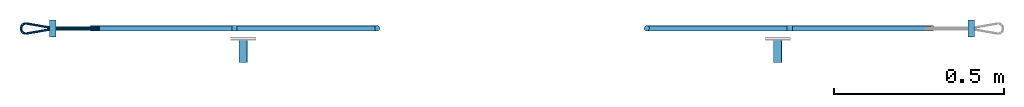
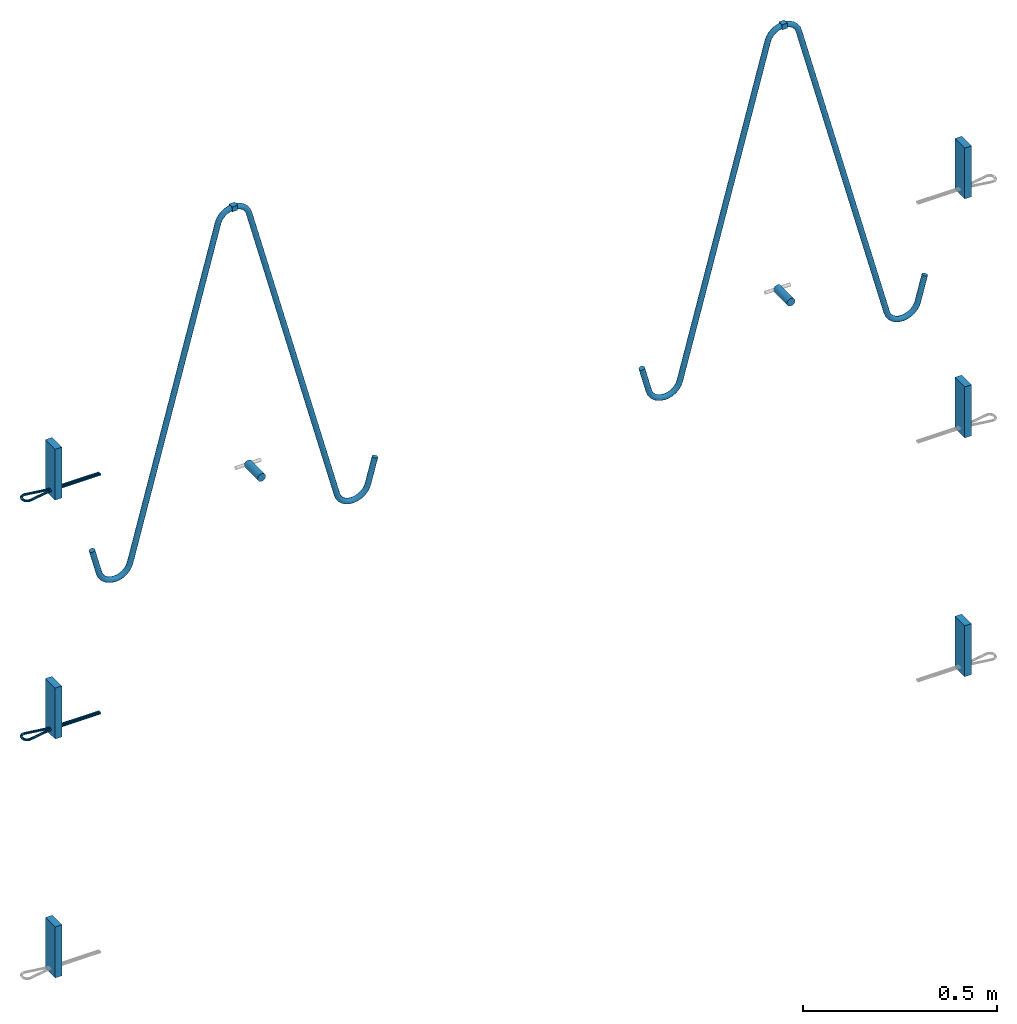
# One storey, part 1 of 2: 6 plates, 4 beams, 4 reinforcing bars, 10 elements without a shape of their own.
"""IFC2X3 building model written with IfcOpenShell, lengths in millimetres."""

from ifc_helpers import new_model, entity, si_unit, frame, frame_2d, origin_with_axes, place, context, subcontext, project, spatial, polyline, rectangle, circle, outline, extrude, source, transform, mapped, material, type_object, element, aggregate, save


model = new_model("IFC2X3")

# Units and contexts
model_context = context("Model", 3, precision=1e-05, world=origin_with_axes())
body_context = subcontext(model_context, "Body", "Model", "MODEL_VIEW")
ifc_project = project(units=[si_unit("LENGTHUNIT", "METRE", prefix="MILLI"), si_unit("AREAUNIT", "SQUARE_METRE"), si_unit("VOLUMEUNIT", "CUBIC_METRE"), si_unit("MASSUNIT", "GRAM", prefix="KILO"), si_unit("TIMEUNIT", "SECOND"), si_unit("PLANEANGLEUNIT", "RADIAN"), si_unit("SOLIDANGLEUNIT", "STERADIAN"), si_unit("THERMODYNAMICTEMPERATUREUNIT", "DEGREE_CELSIUS"), si_unit("LUMINOUSINTENSITYUNIT", "LUMEN")], contexts=[model_context])

# Site, building, storey
site_placement = place(None, origin_with_axes())
site = spatial("IfcSite", under=ifc_project, at=site_placement, CompositionType="ELEMENT")
building_placement = place(site_placement, origin_with_axes())
building = spatial("IfcBuilding", under=site, at=building_placement, Name="Undefined", CompositionType="ELEMENT")
storey_placement = place(building_placement, origin_with_axes())
storey = spatial("IfcBuildingStorey", under=building, at=storey_placement, Name="Undefined", CompositionType="ELEMENT", Elevation=0.0)

# Assembly, beam
assembly_1_placement = place(storey_placement, origin_with_axes())
assembly_1 = element("IfcElementAssembly", 1, at=assembly_1_placement, inside=storey, Name="Steel Assembly", AssemblyPlace="NOTDEFINED", PredefinedType="RIGID_FRAME")
ifc_material_1 = material(Name="STEEL/S235JR")
beam_type_1 = type_object("IfcBeamType", Name="16X16", PredefinedType="NOTDEFINED")
beam_1_placement = place(assembly_1_placement, frame((38185.0997792359, 100.538788960472, 2796.99979437718), z_axis=(0.0, 0.0, 1.0), x_axis=(-0.999999999974582, 7.12999999981878e-06, -1.1000000085717e-08)))
beam_1 = element("IfcBeam", 2, at=beam_1_placement, type_object=beam_type_1, material=ifc_material_1, Name="SA_16", ObjectType="16X16", context=body_context, shape_type="SweptSolid", body=[
    extrude(rectangle(XDim=16.0, YDim=16.0, at=frame_2d((-2.95871700473072e-08, -3.27418092638254e-10), x_axis=(1.0, 0.0))), frame((15.9999999997114, 6.69320834167074e-22, -4.54747350886464e-13), z_axis=(-1.0, 1.47560875081975e-12, 2.33086648627995e-12), x_axis=(-1.47560875081972e-12, -1.0, 1.02406159234497e-14)), (0.0, 0.0, 1.0), 16.0),
])

assembly_2_placement = place(storey_placement, origin_with_axes())
assembly_2 = element("IfcElementAssembly", 3, at=assembly_2_placement, inside=storey, Name="Steel Assembly", AssemblyPlace="NOTDEFINED", PredefinedType="RIGID_FRAME")
beam_2_placement = place(assembly_2_placement, frame((36536.3494963368, 100.550900671999, 2796.99977627339), z_axis=(0.0, 0.0, 1.0), x_axis=(0.999999999973077, -7.33799999980014e-06, 1.10000000860345e-08)))
beam_2 = element("IfcBeam", 4, at=beam_2_placement, type_object=beam_type_1, material=ifc_material_1, Name="SA_16", ObjectType="16X16", context=body_context, shape_type="SweptSolid", body=[
    extrude(rectangle(XDim=16.0, YDim=16.0, at=frame_2d((-2.95871700473072e-08, -3.27418092638254e-10), x_axis=(1.0, 0.0))), frame((15.9999999997114, 6.69320834167074e-22, -4.54747350886464e-13), z_axis=(-1.0, 1.47560875081975e-12, 2.33086648627995e-12), x_axis=(-1.47560875081972e-12, -1.0, 1.02406159234497e-14)), (0.0, 0.0, 1.0), 16.0),
])

assembly_3_placement = place(storey_placement, origin_with_axes())
assembly_3 = element("IfcElementAssembly", 5, at=assembly_3_placement, inside=storey, Name="Steel Assembly", AssemblyPlace="NOTDEFINED", PredefinedType="RIGID_FRAME")
beam_type_2 = type_object("IfcBeamType", Name="D24", PredefinedType="NOTDEFINED")
beam_3_placement = place(assembly_3_placement, frame((38142.136472481, -0.0238731479991401, 1999.99979398687), z_axis=(0.0, 0.0, 1.0), x_axis=(7.33799999579833e-06, 0.999999999973077, 0.0)))
beam_3 = element("IfcBeam", 6, at=beam_3_placement, type_object=beam_type_2, material=ifc_material_1, ObjectType="D24", context=body_context, shape_type="SweptSolid", body=[
    extrude(circle(Radius=12.0, at=frame_2d((-2.95871700473072e-08, -3.27418092638254e-10), x_axis=(1.0, 0.0))), frame((69.9999999988867, 0.0, -2.27373675443232e-13), z_axis=(-1.0, 1.47560875081975e-12, 2.33086648627995e-12), x_axis=(-1.47560875081972e-12, -1.0, 1.02406159234497e-14)), (0.0, 0.0, 1.0), 70.0),
])
aggregate(assembly_3, [beam_3])

assembly_4_placement = place(storey_placement, origin_with_axes())
assembly_4 = element("IfcElementAssembly", 7, at=assembly_4_placement, inside=storey, Name="Steel Assembly", AssemblyPlace="NOTDEFINED", PredefinedType="RIGID_FRAME")
beam_4_placement = place(assembly_4_placement, frame((36569.99647256, -0.00839933236845525, 1999.99977669372), z_axis=(0.0, 0.0, 1.0), x_axis=(7.33799999579833e-06, 0.999999999973077, 0.0)))
beam_4 = element("IfcBeam", 8, at=beam_4_placement, type_object=beam_type_2, material=ifc_material_1, ObjectType="D24", context=body_context, shape_type="SweptSolid", body=[
    extrude(circle(Radius=12.0, at=frame_2d((-2.95871700473072e-08, -3.27418092638254e-10), x_axis=(1.0, 0.0))), frame((69.9999999988867, 0.0, -2.27373675443232e-13), z_axis=(-1.0, 1.47560875081975e-12, 2.33086648627995e-12), x_axis=(-1.47560875081972e-12, -1.0, 1.02406159234497e-14)), (0.0, 0.0, 1.0), 70.0),
])
aggregate(assembly_4, [beam_4])

# Assembly, plate
assembly_5_placement = place(storey_placement, origin_with_axes())
assembly_5 = element("IfcElementAssembly", 9, at=assembly_5_placement, inside=storey, Name="Steel Assembly", AssemblyPlace="NOTDEFINED", PredefinedType="RIGID_FRAME")
ifc_material_2 = material(Name="STEEL/Steel_Undefined")
plate_type = type_object("IfcPlateType", Name="PL160X20", PredefinedType="NOTDEFINED")
plate_1_placement = place(assembly_5_placement, frame((38721.2513597076, 124.979744641962, 2162.49980033677), z_axis=(1.10000000856349e-08, -7.84300007522065e-14, -1.0), x_axis=(-7.13000001269421e-06, -0.999999999974582, 0.0)))
plate_1 = element("IfcPlate", 10, at=plate_1_placement, type_object=plate_type, material=ifc_material_2, Name="PVL80", ObjectType="PL160X20", context=body_context, shape_type="SweptSolid", body=[
    extrude(outline(polyline([(-2.95871700473072e-08, -3.27418092638254e-10), (49.9999999704114, -1.38243194669485e-10), (49.9999999704492, 20.000000000291), (-2.96426065915512e-08, 20.0000000001019), (-2.95871700473072e-08, -3.27418092638254e-10)])), frame((-1.0097419586829e-27, -7.27595761418343e-12, -80.0), z_axis=(0.0, 0.0, 1.0), x_axis=(1.0, 0.0, 0.0)), (0.0, 0.0, 1.0), 160.0),
])
aggregate(assembly_5, [plate_1])

assembly_6_placement = place(storey_placement, origin_with_axes())
assembly_6 = element("IfcElementAssembly", 11, at=assembly_6_placement, inside=storey, Name="Steel Assembly", AssemblyPlace="NOTDEFINED", PredefinedType="RIGID_FRAME")
plate_2_placement = place(assembly_6_placement, frame((38721.2513679684, 124.979744980204, 1412.49980033928), z_axis=(1.10000000856349e-08, -7.84300007522065e-14, -1.0), x_axis=(-7.13000001269421e-06, -0.999999999974582, 0.0)))
plate_2 = element("IfcPlate", 12, at=plate_2_placement, type_object=plate_type, material=ifc_material_2, Name="PVL80", ObjectType="PL160X20", context=body_context, shape_type="SweptSolid", body=[
    extrude(outline(polyline([(-2.95871700473072e-08, -3.27418092638254e-10), (49.9999999704114, -1.38243194669485e-10), (49.9999999704492, 20.000000000291), (-2.96426065915512e-08, 20.0000000001019), (-2.95871700473072e-08, -3.27418092638254e-10)])), frame((-1.0097419586829e-27, -7.27595761418343e-12, -80.0), z_axis=(0.0, 0.0, 1.0), x_axis=(1.0, 0.0, 0.0)), (0.0, 0.0, 1.0), 160.0),
])
aggregate(assembly_6, [plate_2])

assembly_7_placement = place(storey_placement, origin_with_axes())
assembly_7 = element("IfcElementAssembly", 13, at=assembly_7_placement, inside=storey, Name="Steel Assembly", AssemblyPlace="NOTDEFINED", PredefinedType="RIGID_FRAME")
plate_3_placement = place(assembly_7_placement, frame((38721.2513762134, 124.979745351619, 662.499800336753), z_axis=(1.10000000856349e-08, -7.84300007522065e-14, -1.0), x_axis=(-7.13000001269421e-06, -0.999999999974582, 0.0)))
plate_3 = element("IfcPlate", 14, at=plate_3_placement, type_object=plate_type, material=ifc_material_2, Name="PVL80", ObjectType="PL160X20", context=body_context, shape_type="SweptSolid", body=[
    extrude(outline(polyline([(-2.95871700473072e-08, -3.27418092638254e-10), (49.9999999704114, -1.38243194669485e-10), (49.9999999704492, 20.000000000291), (-2.96426065915512e-08, 20.0000000001019), (-2.95871700473072e-08, -3.27418092638254e-10)])), frame((-1.0097419586829e-27, -7.27595761418343e-12, -80.0), z_axis=(0.0, 0.0, 1.0), x_axis=(1.0, 0.0, 0.0)), (0.0, 0.0, 1.0), 160.0),
])
aggregate(assembly_7, [plate_3])

assembly_8_placement = place(storey_placement, origin_with_axes())
assembly_8 = element("IfcElementAssembly", 15, at=assembly_8_placement, inside=storey, Name="Steel Assembly", AssemblyPlace="NOTDEFINED", PredefinedType="RIGID_FRAME")
plate_4_placement = place(assembly_8_placement, frame((36000.0005263411, 74.9997413660697, 2162.49977037731), z_axis=(1.10000000856349e-08, -7.84300007522065e-14, -1.0), x_axis=(7.33799999579833e-06, 0.999999999973077, 0.0)))
plate_4 = element("IfcPlate", 16, at=plate_4_placement, type_object=plate_type, material=ifc_material_2, Name="PVL80", ObjectType="PL160X20", context=body_context, shape_type="SweptSolid", body=[
    extrude(outline(polyline([(-2.95871700473072e-08, -3.27418092638254e-10), (49.9999999704114, -1.38243194669485e-10), (49.9999999704492, 20.000000000291), (-2.96426065915512e-08, 20.0000000001019), (-2.95871700473072e-08, -3.27418092638254e-10)])), frame((-1.0097419586829e-27, -7.27595761418343e-12, -80.0), z_axis=(0.0, 0.0, 1.0), x_axis=(1.0, 0.0, 0.0)), (0.0, 0.0, 1.0), 160.0),
])

assembly_9_placement = place(storey_placement, origin_with_axes())
assembly_9 = element("IfcElementAssembly", 17, at=assembly_9_placement, inside=storey, Name="Steel Assembly", AssemblyPlace="NOTDEFINED", PredefinedType="RIGID_FRAME")
plate_5_placement = place(assembly_9_placement, frame((36000.0005345941, 74.9997417209221, 1412.49977037732), z_axis=(1.10000000856349e-08, -7.84300007522065e-14, -1.0), x_axis=(7.33799999579833e-06, 0.999999999973077, 0.0)))
plate_5 = element("IfcPlate", 18, at=plate_5_placement, type_object=plate_type, material=ifc_material_2, Name="PVL80", ObjectType="PL160X20", context=body_context, shape_type="SweptSolid", body=[
    extrude(outline(polyline([(-2.95871700473072e-08, -3.27418092638254e-10), (49.9999999704114, -1.38243194669485e-10), (49.9999999704492, 20.000000000291), (-2.96426065915512e-08, 20.0000000001019), (-2.95871700473072e-08, -3.27418092638254e-10)])), frame((-1.0097419586829e-27, -7.27595761418343e-12, -80.0), z_axis=(0.0, 0.0, 1.0), x_axis=(1.0, 0.0, 0.0)), (0.0, 0.0, 1.0), 160.0),
])

assembly_10_placement = place(storey_placement, origin_with_axes())
assembly_10 = element("IfcElementAssembly", 19, at=assembly_10_placement, inside=storey, Name="Steel Assembly", AssemblyPlace="NOTDEFINED", PredefinedType="RIGID_FRAME")
plate_6_placement = place(assembly_10_placement, frame((36000.000542847, 74.9997420757317, 662.499770377318), z_axis=(1.10000000856349e-08, -7.84300007522065e-14, -1.0), x_axis=(7.33799999579833e-06, 0.999999999973077, 0.0)))
plate_6 = element("IfcPlate", 20, at=plate_6_placement, type_object=plate_type, material=ifc_material_2, Name="PVL80", ObjectType="PL160X20", context=body_context, shape_type="SweptSolid", body=[
    extrude(outline(polyline([(-2.95871700473072e-08, -3.27418092638254e-10), (49.9999999704114, -1.38243194669485e-10), (49.9999999704492, 20.000000000291), (-2.96426065915512e-08, 20.0000000001019), (-2.95871700473072e-08, -3.27418092638254e-10)])), frame((-1.0097419586829e-27, -7.27595761418343e-12, -80.0), z_axis=(0.0, 0.0, 1.0), x_axis=(1.0, 0.0, 0.0)), (0.0, 0.0, 1.0), 160.0),
])
aggregate(assembly_10, [plate_6])

# Reinforcing bar
ifc_material_3 = material(Name="Undefined")
ifc_direction_1 = entity("IfcDirection", [-1.0, 1.47560875081975e-12, 2.33086648627995e-12])
ifc_direction_2 = entity("IfcDirection", [-1.47560875081972e-12, -1.0, 1.02406159234497e-14])
ifc_direction_3 = entity("IfcDirection", [0.0, 0.0, 1.0])
ifc_direction_4 = entity("IfcDirection", [0.0, 1.0, 0.0])
shared_shape_1 = source(origin_with_axes(), body_context, "Body", "AdvancedSweptSolid", [
    entity("IfcSweptDiskSolid", entity("IfcCompositeCurve", [entity("IfcCompositeCurveSegment", "CONTINUOUS", True, entity("IfcTrimmedCurve", entity("IfcLine", entity("IfcCartesianPoint", [0.0, 0.0, 0.0]), entity("IfcVector", ifc_direction_1, 1.0)), [entity("IfcParameterValue", 0.0)], [entity("IfcParameterValue", 145.829645725194)], True, "PARAMETER")), entity("IfcCompositeCurveSegment", "CONTINUOUS", True, entity("IfcTrimmedCurve", entity("IfcCircle", entity("IfcAxis2Placement3D", entity("IfcCartesianPoint", [-145.829645727792, 2.15049253049908e-10, -13.4999999996601]), ifc_direction_2, ifc_direction_3), 13.5), [entity("IfcParameterValue", 0.0)], [entity("IfcParameterValue", 0.172953396989496)], True, "PARAMETER")), entity("IfcCompositeCurveSegment", "CONTINUOUS", True, entity("IfcTrimmedCurve", entity("IfcLine", entity("IfcCartesianPoint", [-148.152893533644, 2.18613643604162e-10, -0.201409110674614]), entity("IfcVector", entity("IfcDirection", [-0.985080806591517, 1.45183152599139e-12, -0.172092430063053]), 1.0)), [entity("IfcParameterValue", 0.0)], [entity("IfcParameterValue", 67.0237996921062)], True, "PARAMETER")), entity("IfcCompositeCurveSegment", "CONTINUOUS", True, entity("IfcTrimmedCurve", entity("IfcCircle", entity("IfcAxis2Placement3D", entity("IfcCartesianPoint", [-216.500000002484, 3.19344957439298e-10, 1.56289321698179]), ifc_direction_4, entity("IfcDirection", [0.172092430063053, -2.53633218389051e-13, -0.985080806591517])), 13.5), [entity("IfcParameterValue", 0.0)], [entity("IfcParameterValue", 1.74374972377907)], True, "PARAMETER")), entity("IfcCompositeCurveSegment", "CONTINUOUS", True, entity("IfcTrimmedCurve", entity("IfcLine", entity("IfcCartesianPoint", [-230.000000002484, 3.39241523761302e-10, 1.56289321697337]), entity("IfcVector", ifc_direction_3, 1.0)), [entity("IfcParameterValue", 0.0)], [entity("IfcParameterValue", 2.87421356693589)], True, "PARAMETER")), entity("IfcCompositeCurveSegment", "CONTINUOUS", True, entity("IfcTrimmedCurve", entity("IfcCircle", entity("IfcAxis2Placement3D", entity("IfcCartesianPoint", [-216.500000002486, 3.19344957439299e-10, 4.43710678401381]), ifc_direction_4, ifc_direction_1), 13.5), [entity("IfcParameterValue", 0.0)], [entity("IfcParameterValue", 1.74374972378939)], True, "PARAMETER")), entity("IfcCompositeCurveSegment", "CONTINUOUS", True, entity("IfcTrimmedCurve", entity("IfcLine", entity("IfcCartesianPoint", [-214.176752196575, 3.15920908990935e-10, 17.7356976729889]), entity("IfcVector", entity("IfcDirection", [0.985080806590746, -1.45183152598987e-12, -0.172092430067466]), 1.0)), [entity("IfcParameterValue", 0.0)], [entity("IfcParameterValue", 67.0237996920936)], True, "PARAMETER")), entity("IfcCompositeCurveSegment", "CONTINUOUS", True, entity("IfcTrimmedCurve", entity("IfcCircle", entity("IfcAxis2Placement3D", entity("IfcCartesianPoint", [-145.829645727731, 2.15049253049787e-10, 19.5000000003398]), ifc_direction_2, entity("IfcDirection", [-0.172092430067466, 2.64028929953437e-13, -0.985080806590746])), 13.5), [entity("IfcParameterValue", 0.0)], [entity("IfcParameterValue", 0.172953396989178)], True, "PARAMETER")), entity("IfcCompositeCurveSegment", "DISCONTINUOUS", True, entity("IfcTrimmedCurve", entity("IfcLine", entity("IfcCartesianPoint", [-145.829645727762, 2.1518750136483e-10, 6.00000000033984]), entity("IfcVector", entity("IfcDirection", [1.0, 0.0, 0.0]), 1.0)), [entity("IfcParameterValue", 0.0)], [entity("IfcParameterValue", 145.829645725189)], True, "PARAMETER"))], False), 3.5, None, 0.0, 432.414510643066),
])
reinforcing_bar_1_placement = place(assembly_8_placement, frame((36000.0007324906, 102.999741394926, 2099.99977039057), z_axis=(7.33799999579833e-06, 0.999999999973077, 0.0), x_axis=(0.999999999973077, -7.33799999980014e-06, 1.10000000860345e-08)))
reinforcing_bar_1 = element("IfcReinforcingBar", 21, at=reinforcing_bar_1_placement, material=ifc_material_3, Name="PVL80", BarRole="NOTDEFINED", CrossSectionArea=0.0, NominalDiameter=7.0, context=body_context, shape_type="MappedRepresentation", body=[
    mapped(shared_shape_1, transform((147.000000001586, -2.16914486372843e-10, -6.00000000034257))),
])

aggregate(assembly_8, [plate_4, reinforcing_bar_1])

ifc_direction_5 = entity("IfcDirection", [-1.0, 1.47560875081975e-12, 2.33086648627995e-12])
ifc_direction_6 = entity("IfcDirection", [-1.47560875081972e-12, -1.0, 1.02406159234497e-14])
ifc_direction_7 = entity("IfcDirection", [0.0, 0.0, 1.0])
ifc_direction_8 = entity("IfcDirection", [0.0, 1.0, 0.0])
shared_shape_2 = source(origin_with_axes(), body_context, "Body", "AdvancedSweptSolid", [
    entity("IfcSweptDiskSolid", entity("IfcCompositeCurve", [entity("IfcCompositeCurveSegment", "CONTINUOUS", True, entity("IfcTrimmedCurve", entity("IfcLine", entity("IfcCartesianPoint", [0.0, 0.0, 0.0]), entity("IfcVector", ifc_direction_5, 1.0)), [entity("IfcParameterValue", 0.0)], [entity("IfcParameterValue", 145.829645725187)], True, "PARAMETER")), entity("IfcCompositeCurveSegment", "CONTINUOUS", True, entity("IfcTrimmedCurve", entity("IfcCircle", entity("IfcAxis2Placement3D", entity("IfcCartesianPoint", [-145.829645727792, 2.15049253049908e-10, -13.4999999996601]), ifc_direction_6, ifc_direction_7), 13.5), [entity("IfcParameterValue", 0.0)], [entity("IfcParameterValue", 0.17295339698948)], True, "PARAMETER")), entity("IfcCompositeCurveSegment", "CONTINUOUS", True, entity("IfcTrimmedCurve", entity("IfcLine", entity("IfcCartesianPoint", [-148.152893533644, 2.18613643604162e-10, -0.201409110674614]), entity("IfcVector", entity("IfcDirection", [-0.985080806591517, 1.45183152599139e-12, -0.172092430063053]), 1.0)), [entity("IfcParameterValue", 0.0)], [entity("IfcParameterValue", 67.0237996921102)], True, "PARAMETER")), entity("IfcCompositeCurveSegment", "CONTINUOUS", True, entity("IfcTrimmedCurve", entity("IfcCircle", entity("IfcAxis2Placement3D", entity("IfcCartesianPoint", [-216.500000002484, 3.19344957439298e-10, 1.56289321698179]), ifc_direction_8, entity("IfcDirection", [0.172092430063053, -2.53633218389051e-13, -0.985080806591517])), 13.5), [entity("IfcParameterValue", 0.0)], [entity("IfcParameterValue", 1.74374972377933)], True, "PARAMETER")), entity("IfcCompositeCurveSegment", "CONTINUOUS", True, entity("IfcTrimmedCurve", entity("IfcLine", entity("IfcCartesianPoint", [-230.000000002484, 3.39241523761302e-10, 1.56289321697337]), entity("IfcVector", ifc_direction_7, 1.0)), [entity("IfcParameterValue", 0.0)], [entity("IfcParameterValue", 2.87421356693591)], True, "PARAMETER")), entity("IfcCompositeCurveSegment", "CONTINUOUS", True, entity("IfcTrimmedCurve", entity("IfcCircle", entity("IfcAxis2Placement3D", entity("IfcCartesianPoint", [-216.500000002486, 3.19344957439299e-10, 4.43710678401381]), ifc_direction_8, ifc_direction_5), 13.5), [entity("IfcParameterValue", 0.0)], [entity("IfcParameterValue", 1.74374972378913)], True, "PARAMETER")), entity("IfcCompositeCurveSegment", "CONTINUOUS", True, entity("IfcTrimmedCurve", entity("IfcLine", entity("IfcCartesianPoint", [-214.176752196575, 3.15920908990935e-10, 17.7356976729889]), entity("IfcVector", entity("IfcDirection", [0.985080806590746, -1.45183152598987e-12, -0.172092430067466]), 1.0)), [entity("IfcParameterValue", 0.0)], [entity("IfcParameterValue", 67.0237996920896)], True, "PARAMETER")), entity("IfcCompositeCurveSegment", "CONTINUOUS", True, entity("IfcTrimmedCurve", entity("IfcCircle", entity("IfcAxis2Placement3D", entity("IfcCartesianPoint", [-145.829645727731, 2.15049253049787e-10, 19.5000000003398]), ifc_direction_6, entity("IfcDirection", [-0.172092430067466, 2.64028929953437e-13, -0.985080806590746])), 13.5), [entity("IfcParameterValue", 0.0)], [entity("IfcParameterValue", 0.172953396989195)], True, "PARAMETER")), entity("IfcCompositeCurveSegment", "DISCONTINUOUS", True, entity("IfcTrimmedCurve", entity("IfcLine", entity("IfcCartesianPoint", [-145.829645727762, 2.1518750136483e-10, 6.00000000033984]), entity("IfcVector", entity("IfcDirection", [1.0, 0.0, 0.0]), 1.0)), [entity("IfcParameterValue", 0.0)], [entity("IfcParameterValue", 145.829645725196)], True, "PARAMETER"))], False), 3.5, None, 0.0, 432.414510643066),
])
reinforcing_bar_2_placement = place(assembly_9_placement, frame((36000.0007407435, 102.999741749735, 1349.99977039057), z_axis=(7.33799999579833e-06, 0.999999999973077, 0.0), x_axis=(0.999999999973077, -7.33799999980014e-06, 1.10000000860345e-08)))
reinforcing_bar_2 = element("IfcReinforcingBar", 22, at=reinforcing_bar_2_placement, material=ifc_material_3, Name="PVL80", BarRole="NOTDEFINED", CrossSectionArea=0.0, NominalDiameter=7.0, context=body_context, shape_type="MappedRepresentation", body=[
    mapped(shared_shape_2, transform((147.000000001586, -2.16914486372843e-10, -6.00000000034257))),
])

aggregate(assembly_9, [plate_5, reinforcing_bar_2])

ifc_material_4 = material(Name="S235JR")
ifc_direction_9 = entity("IfcDirection", [-0.866025403788111, 1.27183234510086e-12, -0.49999999999364])
vector_1 = entity("IfcVector", ifc_direction_9, 1.0)
ifc_direction_10 = entity("IfcDirection", [-1.47560875081972e-12, -1.0, 1.02406159234497e-14])
ifc_direction_11 = entity("IfcDirection", [-0.49999999999364, -2.91176574116577e-12, 0.866025403788111])
vector_2 = entity("IfcVector", entity("IfcDirection", [1.0, 0.0, 0.0]), 1.0)
ifc_direction_12 = entity("IfcDirection", [0.0, 1.0, 0.0])
shared_shape_3 = source(origin_with_axes(), body_context, "Body", "AdvancedSweptSolid", [
    entity("IfcSweptDiskSolid", entity("IfcCompositeCurve", [entity("IfcCompositeCurveSegment", "CONTINUOUS", True, entity("IfcTrimmedCurve", entity("IfcLine", entity("IfcCartesianPoint", [0.0, 0.0, 0.0]), vector_1), [entity("IfcParameterValue", 0.0)], [entity("IfcParameterValue", 81.1547005379819)], True, "PARAMETER")), entity("IfcCompositeCurveSegment", "CONTINUOUS", True, entity("IfcTrimmedCurve", entity("IfcCircle", entity("IfcAxis2Placement3D", entity("IfcCartesianPoint", [-47.2820323030016, 2.37156397194805e-10, -80.4145188427279]), ifc_direction_10, ifc_direction_11), 46.0), [entity("IfcParameterValue", 0.0)], [entity("IfcParameterValue", 1.04719755120166)], True, "PARAMETER")), entity("IfcCompositeCurveSegment", "CONTINUOUS", True, entity("IfcTrimmedCurve", entity("IfcLine", entity("IfcCartesianPoint", [-93.2820323030016, 2.20851984678483e-10, -80.4145188426229]), entity("IfcVector", entity("IfcDirection", [1.10000000856349e-08, -7.84300007522065e-14, -1.0]), 1.0)), [entity("IfcParameterValue", 0.0)], [entity("IfcParameterValue", 3.15470053741093)], True, "PARAMETER")), entity("IfcCompositeCurveSegment", "CONTINUOUS", True, entity("IfcTrimmedCurve", entity("IfcCircle", entity("IfcAxis2Placement3D", entity("IfcCartesianPoint", [-47.2820323030088, 2.65631286289115e-10, -83.5692193801388]), ifc_direction_10, entity("IfcDirection", [-1.0, 1.47560875081975e-12, 2.33086648627995e-12])), 46.0), [entity("IfcParameterValue", 0.0)], [entity("IfcParameterValue", 1.57079632679477)], True, "PARAMETER")), entity("IfcCompositeCurveSegment", "CONTINUOUS", True, entity("IfcTrimmedCurve", entity("IfcLine", entity("IfcCartesianPoint", [-47.2820323031198, 4.10879932905577e-10, -129.569219380139]), vector_2), [entity("IfcParameterValue", 0.0)], [entity("IfcParameterValue", 1010.03909476361)], True, "PARAMETER")), entity("IfcCompositeCurveSegment", "CONTINUOUS", True, entity("IfcTrimmedCurve", entity("IfcCircle", entity("IfcAxis2Placement3D", entity("IfcCartesianPoint", [962.757062460381, 1.29449176186537e-09, -175.569219382577]), ifc_direction_12, entity("IfcDirection", [0.0, 0.0, 1.0])), 46.0), [entity("IfcParameterValue", 0.0)], [entity("IfcParameterValue", 1.30899693899233)], True, "PARAMETER")), entity("IfcCompositeCurveSegment", "CONTINUOUS", True, entity("IfcTrimmedCurve", entity("IfcLine", entity("IfcCartesianPoint", [1007.18965046967, 1.29729856486983e-09, -163.663543307816]), entity("IfcVector", entity("IfcDirection", [0.258819045103486, 2.69677428345808e-12, -0.96592582628881]), 1.0)), [entity("IfcParameterValue", 0.0)], [entity("IfcParameterValue", 3.06930795083718)], True, "PARAMETER")), entity("IfcCompositeCurveSegment", "CONTINUOUS", True, entity("IfcTrimmedCurve", entity("IfcCircle", entity("IfcAxis2Placement3D", entity("IfcCartesianPoint", [963.551457813345, 1.33522325128369e-09, -178.533943201124]), ifc_direction_12, entity("IfcDirection", [0.96592582628881, -6.44509905739902e-13, 0.258819045103484])), 46.0), [entity("IfcParameterValue", 0.0)], [entity("IfcParameterValue", 1.30899693900886)], True, "PARAMETER")), entity("IfcCompositeCurveSegment", "CONTINUOUS", True, entity("IfcTrimmedCurve", entity("IfcLine", entity("IfcCartesianPoint", [986.551457812863, 1.44737458581077e-09, -218.371111775486]), vector_1), [entity("IfcParameterValue", 0.0)], [entity("IfcParameterValue", 1010.03909475363)], True, "PARAMETER")), entity("IfcCompositeCurveSegment", "CONTINUOUS", True, entity("IfcTrimmedCurve", entity("IfcCircle", entity("IfcAxis2Placement3D", entity("IfcCartesianPoint", [134.831942934177, 2.91061395668235e-09, -763.227827716071]), ifc_direction_10, ifc_direction_11), 46.0), [entity("IfcParameterValue", 0.0)], [entity("IfcParameterValue", 1.5707963268043)], True, "PARAMETER")), entity("IfcCompositeCurveSegment", "CONTINUOUS", True, entity("IfcTrimmedCurve", entity("IfcLine", entity("IfcCartesianPoint", [94.9947743600306, 2.97135812085722e-09, -786.227827715963]), entity("IfcVector", entity("IfcDirection", [0.499999999997668, 2.81428660989559e-12, -0.866025403785785]), 1.0)), [entity("IfcParameterValue", 0.0)], [entity("IfcParameterValue", 3.1547005375201)], True, "PARAMETER")), entity("IfcCompositeCurveSegment", "CONTINUOUS", True, entity("IfcTrimmedCurve", entity("IfcCircle", entity("IfcAxis2Placement3D", entity("IfcCartesianPoint", [136.40929320293, 2.93173832254269e-09, -765.9598785229]), ifc_direction_10, ifc_direction_9), 46.0), [entity("IfcParameterValue", 0.0)], [entity("IfcParameterValue", 1.04719755119147)], True, "PARAMETER")), entity("IfcCompositeCurveSegment", "DISCONTINUOUS", True, entity("IfcTrimmedCurve", entity("IfcLine", entity("IfcCartesianPoint", [136.409293202569, 3.06810054753452e-09, -811.9598785229]), vector_2), [entity("IfcParameterValue", 0.0)], [entity("IfcParameterValue", 81.1547005386104)], True, "PARAMETER"))], False), 8.0, None, 0.0, 2199.6202812536),
])
reinforcing_bar_3_placement = place(assembly_1_placement, frame((37857.8095187543, 100.541193235665, 1742.85003165096), z_axis=(-0.965925829218486, 7.09600000161001e-06, 0.258819034072509), x_axis=(0.258819034065528, -1.90100000048715e-06, 0.965925829244551)))
reinforcing_bar_3 = element("IfcReinforcingBar", 23, at=reinforcing_bar_3_placement, material=ifc_material_4, Name="SA_16", BarRole="NOTDEFINED", CrossSectionArea=0.0, NominalDiameter=16.0, context=body_context, shape_type="MappedRepresentation", body=[
    mapped(shared_shape_3, transform((93.2820323031137, -3.76061848328391e-10, 129.569219380028))),
])

aggregate(assembly_1, [beam_1, reinforcing_bar_3])

ifc_direction_13 = entity("IfcDirection", [-0.866025403788111, 1.27183234510086e-12, -0.49999999999364])
vector_3 = entity("IfcVector", ifc_direction_13, 1.0)
ifc_direction_14 = entity("IfcDirection", [-1.47560875081972e-12, -1.0, 1.02406159234497e-14])
ifc_direction_15 = entity("IfcDirection", [-0.49999999999364, -2.91176574116577e-12, 0.866025403788111])
vector_4 = entity("IfcVector", entity("IfcDirection", [1.0, 0.0, 0.0]), 1.0)
ifc_direction_16 = entity("IfcDirection", [0.0, 1.0, 0.0])
shared_shape_4 = source(origin_with_axes(), body_context, "Body", "AdvancedSweptSolid", [
    entity("IfcSweptDiskSolid", entity("IfcCompositeCurve", [entity("IfcCompositeCurveSegment", "CONTINUOUS", True, entity("IfcTrimmedCurve", entity("IfcLine", entity("IfcCartesianPoint", [0.0, 0.0, 0.0]), vector_3), [entity("IfcParameterValue", 0.0)], [entity("IfcParameterValue", 81.154700538312)], True, "PARAMETER")), entity("IfcCompositeCurveSegment", "CONTINUOUS", True, entity("IfcTrimmedCurve", entity("IfcCircle", entity("IfcAxis2Placement3D", entity("IfcCartesianPoint", [-47.2820323030016, 2.37156397194805e-10, -80.4145188427279]), ifc_direction_14, ifc_direction_15), 46.0), [entity("IfcParameterValue", 0.0)], [entity("IfcParameterValue", 1.04719755119652)], True, "PARAMETER")), entity("IfcCompositeCurveSegment", "CONTINUOUS", True, entity("IfcTrimmedCurve", entity("IfcLine", entity("IfcCartesianPoint", [-93.2820323030016, 2.20851984678483e-10, -80.4145188426229]), entity("IfcVector", entity("IfcDirection", [1.10000000856349e-08, -7.84300007522065e-14, -1.0]), 1.0)), [entity("IfcParameterValue", 0.0)], [entity("IfcParameterValue", 3.15470053747104)], True, "PARAMETER")), entity("IfcCompositeCurveSegment", "CONTINUOUS", True, entity("IfcTrimmedCurve", entity("IfcCircle", entity("IfcAxis2Placement3D", entity("IfcCartesianPoint", [-47.2820323030088, 2.65631286289115e-10, -83.5692193801388]), ifc_direction_14, entity("IfcDirection", [-1.0, 1.47560875081975e-12, 2.33086648627995e-12])), 46.0), [entity("IfcParameterValue", 0.0)], [entity("IfcParameterValue", 1.57079632679957)], True, "PARAMETER")), entity("IfcCompositeCurveSegment", "CONTINUOUS", True, entity("IfcTrimmedCurve", entity("IfcLine", entity("IfcCartesianPoint", [-47.2820323031198, 4.10879932905577e-10, -129.569219380139]), vector_4), [entity("IfcParameterValue", 0.0)], [entity("IfcParameterValue", 1010.03909475572)], True, "PARAMETER")), entity("IfcCompositeCurveSegment", "CONTINUOUS", True, entity("IfcTrimmedCurve", entity("IfcCircle", entity("IfcAxis2Placement3D", entity("IfcCartesianPoint", [962.757062460381, 1.29449176186537e-09, -175.569219382577]), ifc_direction_16, entity("IfcDirection", [0.0, 0.0, 1.0])), 46.0), [entity("IfcParameterValue", 0.0)], [entity("IfcParameterValue", 1.3089969390037)], True, "PARAMETER")), entity("IfcCompositeCurveSegment", "CONTINUOUS", True, entity("IfcTrimmedCurve", entity("IfcLine", entity("IfcCartesianPoint", [1007.18965046967, 1.29729856486983e-09, -163.663543307816]), entity("IfcVector", entity("IfcDirection", [0.258819045103486, 2.69677428345808e-12, -0.96592582628881]), 1.0)), [entity("IfcParameterValue", 0.0)], [entity("IfcParameterValue", 3.06930795080222)], True, "PARAMETER")), entity("IfcCompositeCurveSegment", "CONTINUOUS", True, entity("IfcTrimmedCurve", entity("IfcCircle", entity("IfcAxis2Placement3D", entity("IfcCartesianPoint", [963.551457813345, 1.33522325128369e-09, -178.533943201124]), ifc_direction_16, entity("IfcDirection", [0.96592582628881, -6.44509905739902e-13, 0.258819045103484])), 46.0), [entity("IfcParameterValue", 0.0)], [entity("IfcParameterValue", 1.30899693899772)], True, "PARAMETER")), entity("IfcCompositeCurveSegment", "CONTINUOUS", True, entity("IfcTrimmedCurve", entity("IfcLine", entity("IfcCartesianPoint", [986.551457812863, 1.44737458581077e-09, -218.371111775486]), vector_3), [entity("IfcParameterValue", 0.0)], [entity("IfcParameterValue", 1010.03909476176)], True, "PARAMETER")), entity("IfcCompositeCurveSegment", "CONTINUOUS", True, entity("IfcTrimmedCurve", entity("IfcCircle", entity("IfcAxis2Placement3D", entity("IfcCartesianPoint", [134.831942934177, 2.91061395668235e-09, -763.227827716071]), ifc_direction_14, ifc_direction_15), 46.0), [entity("IfcParameterValue", 0.0)], [entity("IfcParameterValue", 1.57079632679997)], True, "PARAMETER")), entity("IfcCompositeCurveSegment", "CONTINUOUS", True, entity("IfcTrimmedCurve", entity("IfcLine", entity("IfcCartesianPoint", [94.9947743600306, 2.97135812085722e-09, -786.227827715963]), entity("IfcVector", entity("IfcDirection", [0.499999999997668, 2.81428660989559e-12, -0.866025403785785]), 1.0)), [entity("IfcParameterValue", 0.0)], [entity("IfcParameterValue", 3.15470053739716)], True, "PARAMETER")), entity("IfcCompositeCurveSegment", "CONTINUOUS", True, entity("IfcTrimmedCurve", entity("IfcCircle", entity("IfcAxis2Placement3D", entity("IfcCartesianPoint", [136.40929320293, 2.93173832254269e-09, -765.9598785229]), ifc_direction_14, ifc_direction_13), 46.0), [entity("IfcParameterValue", 0.0)], [entity("IfcParameterValue", 1.04719755119672)], True, "PARAMETER")), entity("IfcCompositeCurveSegment", "DISCONTINUOUS", True, entity("IfcTrimmedCurve", entity("IfcLine", entity("IfcCartesianPoint", [136.409293202569, 3.06810054753452e-09, -811.9598785229]), vector_4), [entity("IfcParameterValue", 0.0)], [entity("IfcParameterValue", 81.1547005382977)], True, "PARAMETER"))], False), 8.0, None, 0.0, 2199.62028125375),
])
reinforcing_bar_4_placement = place(assembly_2_placement, frame((36863.6397799866, 100.548496395944, 1742.85002074872), z_axis=(0.965925823316563, -7.09600000233481e-06, 0.258819056098788), x_axis=(-0.258819056091806, 1.90100000067406e-06, 0.965925823342627)))
reinforcing_bar_4 = element("IfcReinforcingBar", 24, at=reinforcing_bar_4_placement, material=ifc_material_4, Name="SA_16", BarRole="NOTDEFINED", CrossSectionArea=0.0, NominalDiameter=16.0, context=body_context, shape_type="MappedRepresentation", body=[
    mapped(shared_shape_4, transform((93.2820323031137, -3.76061848328391e-10, 129.569219380028))),
])

aggregate(assembly_2, [beam_2, reinforcing_bar_4])

save(model, "model.ifc")
